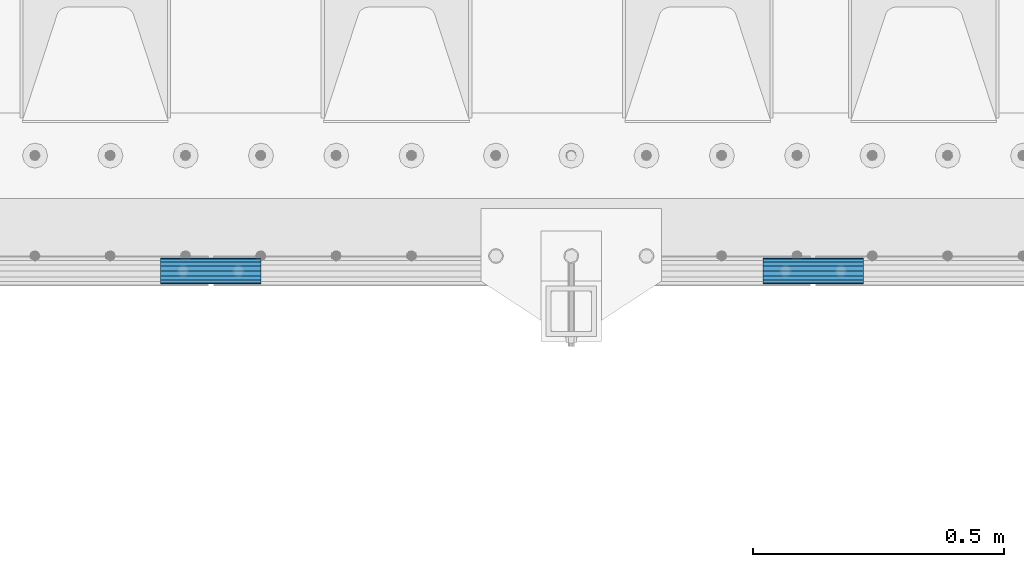
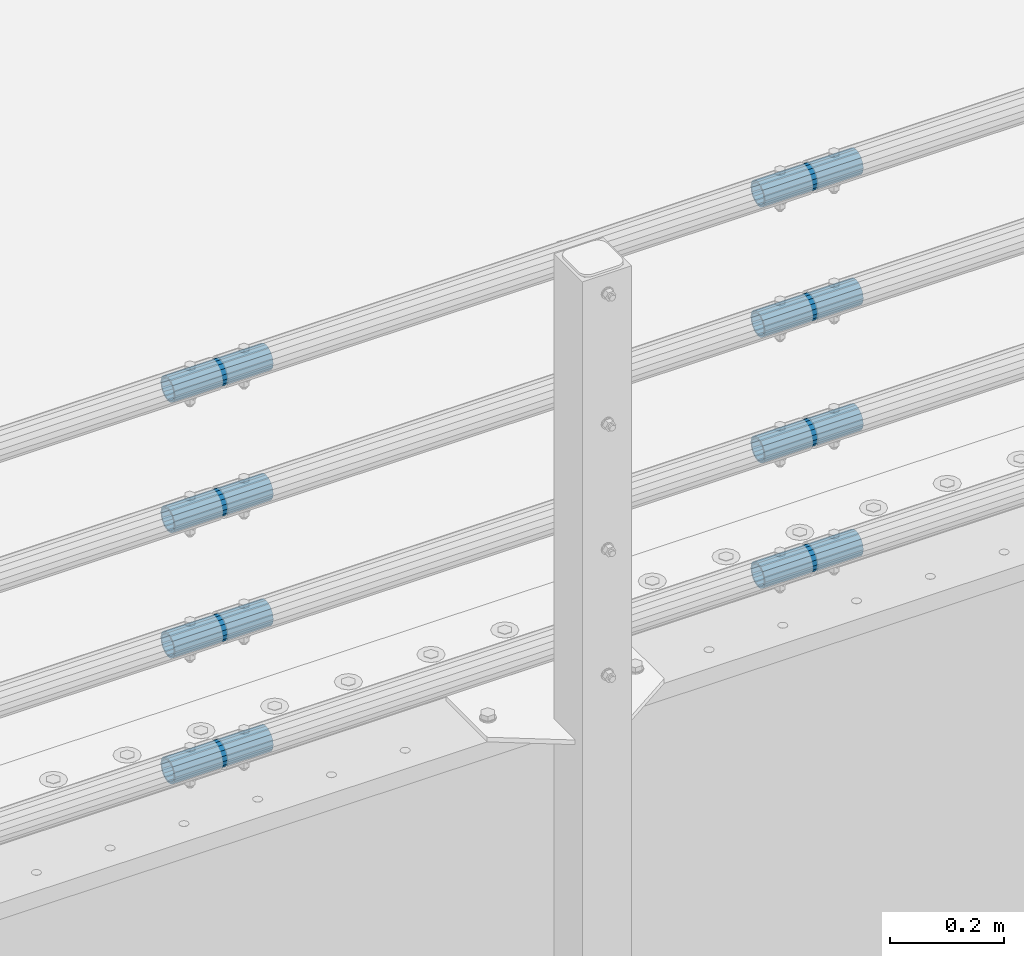
# One storey, part 156 of 242: 8 beams.
"""IFC2X3 building model written with IfcOpenShell, lengths in millimetres."""

import ifcopenshell
import ifcopenshell.guid

model = None  # the IFC model being written
_history = None  # IfcOwnerHistory: only IFC2X3 demands one
_inside = {}  # id of a spatial element -> (the spatial element, [elements in it])
_under = {}  # id of a project, library or spatial element -> (it, [spatial elements below it])
_declared = {}  # id of a project -> (the project, [libraries it declares])
_typed = {}  # id of a type object -> (the type object, [elements of that type])
_made_of = {}  # id of a material, layer set ... -> (it, [elements and type objects made of it])


def new_model(schema):
    """Start an empty IFC model of exactly this schema.

    Asked for "IFC4X3", IfcOpenShell would pick the latest addendum, in which some entities
    have other attributes; the version numbers below select the first issue.
    IFC2X3 requires an IfcOwnerHistory on every rooted entity: one is made here for all.
    """
    global model, _history
    if schema == "IFC4X3":
        model = ifcopenshell.file(schema_version=(4, 3, 0, 0))
    else:
        model = ifcopenshell.file(schema=schema)
    _inside.clear()
    _under.clear()
    _declared.clear()
    _typed.clear()
    _made_of.clear()
    _history = None
    if model.schema == "IFC2X3":
        org = make("IfcOrganization", Name="unknown")
        user = make(
            "IfcPersonAndOrganization",
            ThePerson=make("IfcPerson", FamilyName="unknown"),
            TheOrganization=org,
        )
        app = make(
            "IfcApplication",
            ApplicationDeveloper=org,
            Version="unknown",
            ApplicationFullName="unknown",
            ApplicationIdentifier="unknown",
        )
        _history = make(
            "IfcOwnerHistory",
            OwningUser=user,
            OwningApplication=app,
            ChangeAction="ADDED",
            CreationDate=0,
        )
    return model


def make(cls, **values):
    """One entity of the class cls with the attributes given. An attribute that is None is left unset."""
    return model.create_entity(
        cls, **{name: value for name, value in values.items() if value is not None}
    )


def rooted(cls, **values):
    """An entity with a GlobalId (a new one), such as an element, a storey or a relation."""
    return make(cls, GlobalId=ifcopenshell.guid.new(), OwnerHistory=_history, **values)


def si_unit(unit_type, name, prefix=None):
    """IfcSIUnit, for example si_unit("LENGTHUNIT", "METRE", prefix="MILLI")."""
    return make("IfcSIUnit", UnitType=unit_type, Prefix=prefix, Name=name)


def assignment(units):
    """IfcUnitAssignment: the units of a project."""
    return None if units is None else make("IfcUnitAssignment", Units=units)


def point(xyz):
    """IfcCartesianPoint."""
    return None if xyz is None else make("IfcCartesianPoint", Coordinates=xyz)


def direction(xyz):
    """IfcDirection."""
    return None if xyz is None else make("IfcDirection", DirectionRatios=xyz)


def frame(location, z_axis=None, x_axis=None):
    """IfcAxis2Placement3D, a coordinate frame: its origin and axes. An axis left out is left unset."""
    return make(
        "IfcAxis2Placement3D",
        Location=point(location),
        Axis=direction(z_axis),
        RefDirection=direction(x_axis),
    )


def origin_with_axes():
    """The frame at (0, 0, 0) with the z axis (0, 0, 1) and the x axis (1, 0, 0) written out."""
    return frame((0.0, 0.0, 0.0), z_axis=(0.0, 0.0, 1.0), x_axis=(1.0, 0.0, 0.0))


def place(relative_to, where):
    """IfcLocalPlacement: puts the frame where relative to a parent placement (None: the world)."""
    return make(
        "IfcLocalPlacement", PlacementRelTo=relative_to, RelativePlacement=where
    )


def context(
    kind, dimensions, precision=None, world=None, true_north=None, identifier=None
):
    """IfcGeometricRepresentationContext, for example the 3D "Model" context."""
    return make(
        "IfcGeometricRepresentationContext",
        ContextIdentifier=identifier,
        ContextType=kind,
        CoordinateSpaceDimension=dimensions,
        Precision=precision,
        WorldCoordinateSystem=world,
        TrueNorth=true_north,
    )


def subcontext(parent, identifier, kind, view, scale=None):
    """IfcGeometricRepresentationSubContext, for example "Body" below "Model"."""
    return make(
        "IfcGeometricRepresentationSubContext",
        ContextIdentifier=identifier,
        ContextType=kind,
        ParentContext=parent,
        TargetScale=scale,
        TargetView=view,
    )


def project(units=None, contexts=None):
    """IfcProject with its units and contexts."""
    return rooted(
        "IfcProject",
        Name="project",
        RepresentationContexts=contexts,
        UnitsInContext=assignment(units),
    )


def spatial(cls, under=None, at=None, **own):
    """A site, building, storey or space (cls), placed at a placement, below another one or the project."""
    s = rooted(cls, ObjectPlacement=at, **own)
    if under is not None:
        _under.setdefault(under.id(), (under, []))[1].append(s)
    return s


def faces_of(points, faces, orient=None, outer=None):
    """IfcFace entities. A face is a list of loops; a loop is a list of indices into points, from 0.

    orient and outer hold one flag for each loop. By default every Orientation is true, the
    first loop of a face is its IfcFaceOuterBound and the others are IfcFaceBound.
    """
    made = []
    for i, loops in enumerate(faces):
        bounds = []
        for j, loop in enumerate(loops):
            is_outer = j == 0 if outer is None else outer[i][j]
            bounds.append(
                make(
                    "IfcFaceOuterBound" if is_outer else "IfcFaceBound",
                    Bound=make("IfcPolyLoop", Polygon=[points[k] for k in loop]),
                    Orientation=True if orient is None else orient[i][j],
                )
            )
        made.append(make("IfcFace", Bounds=bounds))
    return made


def faceted_brep(points, faces, orient=None, outer=None, voids=None):
    """IfcFacetedBrep: a solid bounded by flat faces; with voids (closed shells), ...WithVoids."""
    shared = [point(p) for p in points]
    hull = make("IfcClosedShell", CfsFaces=faces_of(shared, faces, orient, outer))
    if voids is None:
        return make("IfcFacetedBrep", Outer=hull)
    return make(
        "IfcFacetedBrepWithVoids",
        Outer=hull,
        Voids=[
            make(cls, CfsFaces=faces_of(shared, fs, o, b)) for cls, fs, o, b in voids
        ],
    )


def shape(context_of_items, identifier, shape_type, items):
    """IfcShapeRepresentation: the items that make up one representation, for example the "Body"."""
    return make(
        "IfcShapeRepresentation",
        ContextOfItems=context_of_items,
        RepresentationIdentifier=identifier,
        RepresentationType=shape_type,
        Items=items,
    )


def material(Name=None, Category=None):
    """IfcMaterial."""
    return make("IfcMaterial", Name=Name, Category=Category)


def made_of(thing, what):
    """Note that an element or type object is made of a material, layer set ...; save() writes the relation."""
    if what is not None:
        _made_of.setdefault(what.id(), (what, []))[1].append(thing)
    return thing


def type_object(cls, material=None, **own):
    """A type object (cls), such as IfcWallType, which elements share."""
    return made_of(rooted(cls, **own), material)


def element(
    cls,
    number,
    at=None,
    inside=None,
    cuts=None,
    type_object=None,
    material=None,
    context=None,
    identifier="Body",
    shape_type=None,
    held_by="IfcProductDefinitionShape",
    body=None,
    shapes=None,
    **own,
):
    """One element of the class cls, such as IfcWall. Its Tag is "e" and its number.

    at: its placement. inside: the storey or other place that contains it. cuts: it is an
    opening in that element (IfcRelVoidsElement). A single representation is given by context,
    identifier, shape_type and body (its items); several are given by shapes. held_by: the class
    of the entity that holds the representations. save() writes the other relations.
    """
    e = rooted(cls, Tag="e%d" % number, ObjectPlacement=at, **own)
    if body is not None:
        shapes = [shape(context, identifier, shape_type, body)]
    if shapes is not None:
        e.Representation = make(held_by, Representations=shapes)
    if inside is not None:
        _inside.setdefault(inside.id(), (inside, []))[1].append(e)
    if cuts is not None:
        rooted(
            "IfcRelVoidsElement", RelatingBuildingElement=cuts, RelatedOpeningElement=e
        )
    if type_object is not None:
        _typed.setdefault(type_object.id(), (type_object, []))[1].append(e)
    return made_of(e, material)


def aggregate(whole, parts):
    """IfcRelAggregates: a whole, such as a stair, and the parts it consists of."""
    return rooted("IfcRelAggregates", RelatingObject=whole, RelatedObjects=parts)


def save(model, path):
    """Write the relations noted so far, then the file.

    IfcRelAggregates (storeys below a building ...), IfcRelContainedInSpatialStructure (elements
    in a storey), IfcRelDefinesByType, IfcRelAssociatesMaterial and IfcRelDeclares: one each for
    every whole, place, type object, material and project.
    """
    for whole, parts in _under.values():
        aggregate(whole, parts)
    for where, things in _inside.values():
        rooted(
            "IfcRelContainedInSpatialStructure",
            RelatedElements=things,
            RelatingStructure=where,
        )
    for kind, things in _typed.values():
        rooted("IfcRelDefinesByType", RelatedObjects=things, RelatingType=kind)
    for what, things in _made_of.values():
        rooted("IfcRelAssociatesMaterial", RelatedObjects=things, RelatingMaterial=what)
    for by, libraries in _declared.values():
        rooted("IfcRelDeclares", RelatingContext=by, RelatedDefinitions=libraries)
    model.write(path)


model = new_model("IFC2X3")

# Units and contexts
model_context = context("Model", 3, precision=1e-05, world=origin_with_axes())
body_context = subcontext(model_context, "Body", "Model", "MODEL_VIEW")
ifc_project = project(units=[si_unit("LENGTHUNIT", "METRE", prefix="MILLI"), si_unit("AREAUNIT", "SQUARE_METRE"), si_unit("VOLUMEUNIT", "CUBIC_METRE"), si_unit("MASSUNIT", "GRAM", prefix="KILO"), si_unit("TIMEUNIT", "SECOND"), si_unit("PLANEANGLEUNIT", "RADIAN"), si_unit("SOLIDANGLEUNIT", "STERADIAN"), si_unit("THERMODYNAMICTEMPERATUREUNIT", "DEGREE_CELSIUS"), si_unit("LUMINOUSINTENSITYUNIT", "LUMEN")], contexts=[model_context])

# Site, building, storey
site_placement = place(None, origin_with_axes())
site = spatial("IfcSite", under=ifc_project, at=site_placement, CompositionType="ELEMENT")
building_placement = place(site_placement, origin_with_axes())
building = spatial("IfcBuilding", under=site, at=building_placement, Name="Standard", CompositionType="ELEMENT")
storey_placement = place(building_placement, origin_with_axes())
storey = spatial("IfcBuildingStorey", under=building, at=storey_placement, Name="Undefined", CompositionType="ELEMENT", Elevation=0.0)

# Beams
ifc_material = material()
beam_type = type_object("IfcBeamType", PredefinedType="NOTDEFINED")
beam_1_placement = place(storey_placement, frame((-24850.0024970001, -24129.8499999996, 149.849999999726), z_axis=(0.0, 0.0, 1.0), x_axis=(1.0, 0.0, 0.0)))
element("IfcBeam", 1, at=beam_1_placement, inside=storey, type_object=beam_type, material=ifc_material, context=body_context, shape_type="Brep", body=[
    faceted_brep([(0.0, -21.9000000000015, 0.0), (0.0, -20.232961761998, 8.38076716879547), (200.0, -20.232961761998, 8.38076716879547), (200.0, -21.9000000000015, 0.0), (0.0, -15.4856385079838, 15.4856385079854), (200.0, -15.4856385079838, 15.4856385079854), (0.0, -8.38076716879368, 20.2329617619972), (200.0, -8.38076716879368, 20.2329617619972), (0.0, 0.0, 21.9), (200.0, 0.0, 21.9), (0.0, 8.38076716879368, 20.2329617619972), (200.0, 8.38076716879368, 20.2329617619972), (0.0, 15.4856385079838, 15.4856385079854), (200.0, 15.4856385079838, 15.4856385079854), (0.0, 20.232961761998, 8.38076716879547), (200.0, 20.232961761998, 8.38076716879547), (0.0, 21.9000000000015, 0.0), (200.0, 21.9000000000015, 0.0), (0.0, 20.232961761998, -8.38076716879547), (200.0, 20.232961761998, -8.38076716879547), (0.0, 15.4856385079838, -15.4856385079854), (200.0, 15.4856385079838, -15.4856385079854), (0.0, 8.38076716879368, -20.2329617619972), (200.0, 8.38076716879368, -20.2329617619972), (0.0, 0.0, -21.9), (200.0, 0.0, -21.9), (0.0, -8.38076716879368, -20.2329617619972), (200.0, -8.38076716879368, -20.2329617619972), (0.0, -15.4856385079838, -15.4856385079854), (200.0, -15.4856385079838, -15.4856385079854), (0.0, -20.232961761998, -8.38076716879547), (200.0, -20.232961761998, -8.38076716879547), (0.0, -25.5, 0.0), (0.0, -23.5589280790373, -9.7584275253098), (200.0, -23.5589280790373, -9.7584275253098), (200.0, -25.5, 0.0), (0.0, -18.0312229202573, -18.031222920257), (200.0, -18.0312229202573, -18.031222920257), (0.0, -9.75842752531025, -23.5589280790378), (200.0, -9.75842752531025, -23.5589280790378), (0.0, 0.0, -25.5), (200.0, 0.0, -25.5), (0.0, 9.75842752531025, -23.5589280790378), (200.0, 9.75842752531025, -23.5589280790378), (0.0, 18.0312229202573, -18.031222920257), (200.0, 18.0312229202573, -18.031222920257), (0.0, 23.5589280790373, -9.7584275253098), (200.0, 23.5589280790373, -9.7584275253098), (0.0, 25.5, 0.0), (200.0, 25.5, 0.0), (0.0, 23.5589280790373, 9.7584275253098), (200.0, 23.5589280790373, 9.7584275253098), (0.0, 18.0312229202573, 18.031222920257), (200.0, 18.0312229202573, 18.031222920257), (0.0, 9.75842752531025, 23.5589280790378), (200.0, 9.75842752531025, 23.5589280790378), (0.0, 0.0, 25.5), (200.0, 0.0, 25.5), (0.0, -9.75842752531025, 23.5589280790378), (200.0, -9.75842752531025, 23.5589280790378), (0.0, -18.0312229202573, 18.031222920257), (200.0, -18.0312229202573, 18.031222920257), (0.0, -23.5589280790373, 9.7584275253098), (200.0, -23.5589280790373, 9.7584275253098)], [[[0, 1, 2, 3]], [[1, 4, 5, 2]], [[4, 6, 7, 5]], [[6, 8, 9, 7]], [[8, 10, 11, 9]], [[10, 12, 13, 11]], [[12, 14, 15, 13]], [[14, 16, 17, 15]], [[16, 18, 19, 17]], [[18, 20, 21, 19]], [[20, 22, 23, 21]], [[22, 24, 25, 23]], [[24, 26, 27, 25]], [[26, 28, 29, 27]], [[28, 30, 31, 29]], [[30, 0, 3, 31]], [[32, 33, 34, 35]], [[33, 36, 37, 34]], [[36, 38, 39, 37]], [[38, 40, 41, 39]], [[40, 42, 43, 41]], [[42, 44, 45, 43]], [[44, 46, 47, 45]], [[46, 48, 49, 47]], [[48, 50, 51, 49]], [[50, 52, 53, 51]], [[52, 54, 55, 53]], [[54, 56, 57, 55]], [[56, 58, 59, 57]], [[58, 60, 61, 59]], [[60, 62, 63, 61]], [[62, 32, 35, 63]], [[37, 39, 41, 43, 45, 47, 49, 51, 53, 55, 57, 59, 61, 63, 35, 34], [5, 7, 9, 11, 13, 15, 17, 19, 21, 23, 25, 27, 29, 31, 3, 2]], [[62, 60, 58, 56, 54, 52, 50, 48, 46, 44, 42, 40, 38, 36, 33, 32], [30, 28, 26, 24, 22, 20, 18, 16, 14, 12, 10, 8, 6, 4, 1, 0]]]),
])
beam_2_placement = place(storey_placement, frame((-24850.0024970001, -24129.8499999996, 420.149999999725), z_axis=(0.0, 0.0, 1.0), x_axis=(1.0, 0.0, 0.0)))
element("IfcBeam", 2, at=beam_2_placement, inside=storey, type_object=beam_type, material=ifc_material, context=body_context, shape_type="Brep", body=[
    faceted_brep([(0.0, -21.9000000000015, 0.0), (0.0, -20.232961761998, 8.38076716879547), (200.0, -20.232961761998, 8.38076716879547), (200.0, -21.9000000000015, 0.0), (0.0, -15.4856385079838, 15.4856385079854), (200.0, -15.4856385079838, 15.4856385079854), (0.0, -8.38076716879368, 20.2329617619972), (200.0, -8.38076716879368, 20.2329617619972), (0.0, 0.0, 21.9), (200.0, 0.0, 21.9), (0.0, 8.38076716879368, 20.2329617619972), (200.0, 8.38076716879368, 20.2329617619972), (0.0, 15.4856385079838, 15.4856385079854), (200.0, 15.4856385079838, 15.4856385079854), (0.0, 20.232961761998, 8.38076716879547), (200.0, 20.232961761998, 8.38076716879547), (0.0, 21.9000000000015, 0.0), (200.0, 21.9000000000015, 0.0), (0.0, 20.232961761998, -8.38076716879547), (200.0, 20.232961761998, -8.38076716879547), (0.0, 15.4856385079838, -15.4856385079854), (200.0, 15.4856385079838, -15.4856385079854), (0.0, 8.38076716879368, -20.2329617619972), (200.0, 8.38076716879368, -20.2329617619972), (0.0, 0.0, -21.9), (200.0, 0.0, -21.9), (0.0, -8.38076716879368, -20.2329617619972), (200.0, -8.38076716879368, -20.2329617619972), (0.0, -15.4856385079838, -15.4856385079854), (200.0, -15.4856385079838, -15.4856385079854), (0.0, -20.232961761998, -8.38076716879547), (200.0, -20.232961761998, -8.38076716879547), (0.0, -25.5, 0.0), (0.0, -23.5589280790373, -9.7584275253098), (200.0, -23.5589280790373, -9.7584275253098), (200.0, -25.5, 0.0), (0.0, -18.0312229202573, -18.031222920257), (200.0, -18.0312229202573, -18.031222920257), (0.0, -9.75842752531025, -23.5589280790378), (200.0, -9.75842752531025, -23.5589280790378), (0.0, 0.0, -25.5), (200.0, 0.0, -25.5), (0.0, 9.75842752531025, -23.5589280790378), (200.0, 9.75842752531025, -23.5589280790378), (0.0, 18.0312229202573, -18.031222920257), (200.0, 18.0312229202573, -18.031222920257), (0.0, 23.5589280790373, -9.7584275253098), (200.0, 23.5589280790373, -9.7584275253098), (0.0, 25.5, 0.0), (200.0, 25.5, 0.0), (0.0, 23.5589280790373, 9.7584275253098), (200.0, 23.5589280790373, 9.7584275253098), (0.0, 18.0312229202573, 18.031222920257), (200.0, 18.0312229202573, 18.031222920257), (0.0, 9.75842752531025, 23.5589280790378), (200.0, 9.75842752531025, 23.5589280790378), (0.0, 0.0, 25.5), (200.0, 0.0, 25.5), (0.0, -9.75842752531025, 23.5589280790378), (200.0, -9.75842752531025, 23.5589280790378), (0.0, -18.0312229202573, 18.031222920257), (200.0, -18.0312229202573, 18.031222920257), (0.0, -23.5589280790373, 9.7584275253098), (200.0, -23.5589280790373, 9.7584275253098)], [[[0, 1, 2, 3]], [[1, 4, 5, 2]], [[4, 6, 7, 5]], [[6, 8, 9, 7]], [[8, 10, 11, 9]], [[10, 12, 13, 11]], [[12, 14, 15, 13]], [[14, 16, 17, 15]], [[16, 18, 19, 17]], [[18, 20, 21, 19]], [[20, 22, 23, 21]], [[22, 24, 25, 23]], [[24, 26, 27, 25]], [[26, 28, 29, 27]], [[28, 30, 31, 29]], [[30, 0, 3, 31]], [[32, 33, 34, 35]], [[33, 36, 37, 34]], [[36, 38, 39, 37]], [[38, 40, 41, 39]], [[40, 42, 43, 41]], [[42, 44, 45, 43]], [[44, 46, 47, 45]], [[46, 48, 49, 47]], [[48, 50, 51, 49]], [[50, 52, 53, 51]], [[52, 54, 55, 53]], [[54, 56, 57, 55]], [[56, 58, 59, 57]], [[58, 60, 61, 59]], [[60, 62, 63, 61]], [[62, 32, 35, 63]], [[37, 39, 41, 43, 45, 47, 49, 51, 53, 55, 57, 59, 61, 63, 35, 34], [5, 7, 9, 11, 13, 15, 17, 19, 21, 23, 25, 27, 29, 31, 3, 2]], [[62, 60, 58, 56, 54, 52, 50, 48, 46, 44, 42, 40, 38, 36, 33, 32], [30, 28, 26, 24, 22, 20, 18, 16, 14, 12, 10, 8, 6, 4, 1, 0]]]),
])
beam_3_placement = place(storey_placement, frame((-24850.0024970001, -24129.8499999996, 969.849999999726), z_axis=(0.0, 0.0, 1.0), x_axis=(1.0, 0.0, 0.0)))
element("IfcBeam", 3, at=beam_3_placement, inside=storey, type_object=beam_type, material=ifc_material, context=body_context, shape_type="Brep", body=[
    faceted_brep([(0.0, -21.9000000000015, 0.0), (0.0, -20.232961761998, 8.38076716879547), (200.0, -20.232961761998, 8.38076716879547), (200.0, -21.9000000000015, 0.0), (0.0, -15.4856385079838, 15.4856385079854), (200.0, -15.4856385079838, 15.4856385079854), (0.0, -8.38076716879368, 20.2329617619972), (200.0, -8.38076716879368, 20.2329617619972), (0.0, 0.0, 21.9), (200.0, 0.0, 21.9), (0.0, 8.38076716879368, 20.2329617619972), (200.0, 8.38076716879368, 20.2329617619972), (0.0, 15.4856385079838, 15.4856385079854), (200.0, 15.4856385079838, 15.4856385079854), (0.0, 20.232961761998, 8.38076716879547), (200.0, 20.232961761998, 8.38076716879547), (0.0, 21.9000000000015, 0.0), (200.0, 21.9000000000015, 0.0), (0.0, 20.232961761998, -8.38076716879547), (200.0, 20.232961761998, -8.38076716879547), (0.0, 15.4856385079838, -15.4856385079854), (200.0, 15.4856385079838, -15.4856385079854), (0.0, 8.38076716879368, -20.2329617619972), (200.0, 8.38076716879368, -20.2329617619972), (0.0, 0.0, -21.9), (200.0, 0.0, -21.9), (0.0, -8.38076716879368, -20.2329617619972), (200.0, -8.38076716879368, -20.2329617619972), (0.0, -15.4856385079838, -15.4856385079854), (200.0, -15.4856385079838, -15.4856385079854), (0.0, -20.232961761998, -8.38076716879547), (200.0, -20.232961761998, -8.38076716879547), (0.0, -25.5, 0.0), (0.0, -23.5589280790373, -9.7584275253098), (200.0, -23.5589280790373, -9.7584275253098), (200.0, -25.5, 0.0), (0.0, -18.0312229202573, -18.031222920257), (200.0, -18.0312229202573, -18.031222920257), (0.0, -9.75842752531025, -23.5589280790378), (200.0, -9.75842752531025, -23.5589280790378), (0.0, 0.0, -25.5), (200.0, 0.0, -25.5), (0.0, 9.75842752531025, -23.5589280790378), (200.0, 9.75842752531025, -23.5589280790378), (0.0, 18.0312229202573, -18.031222920257), (200.0, 18.0312229202573, -18.031222920257), (0.0, 23.5589280790373, -9.7584275253098), (200.0, 23.5589280790373, -9.7584275253098), (0.0, 25.5, 0.0), (200.0, 25.5, 0.0), (0.0, 23.5589280790373, 9.7584275253098), (200.0, 23.5589280790373, 9.7584275253098), (0.0, 18.0312229202573, 18.031222920257), (200.0, 18.0312229202573, 18.031222920257), (0.0, 9.75842752531025, 23.5589280790378), (200.0, 9.75842752531025, 23.5589280790378), (0.0, 0.0, 25.5), (200.0, 0.0, 25.5), (0.0, -9.75842752531025, 23.5589280790378), (200.0, -9.75842752531025, 23.5589280790378), (0.0, -18.0312229202573, 18.031222920257), (200.0, -18.0312229202573, 18.031222920257), (0.0, -23.5589280790373, 9.7584275253098), (200.0, -23.5589280790373, 9.7584275253098)], [[[0, 1, 2, 3]], [[1, 4, 5, 2]], [[4, 6, 7, 5]], [[6, 8, 9, 7]], [[8, 10, 11, 9]], [[10, 12, 13, 11]], [[12, 14, 15, 13]], [[14, 16, 17, 15]], [[16, 18, 19, 17]], [[18, 20, 21, 19]], [[20, 22, 23, 21]], [[22, 24, 25, 23]], [[24, 26, 27, 25]], [[26, 28, 29, 27]], [[28, 30, 31, 29]], [[30, 0, 3, 31]], [[32, 33, 34, 35]], [[33, 36, 37, 34]], [[36, 38, 39, 37]], [[38, 40, 41, 39]], [[40, 42, 43, 41]], [[42, 44, 45, 43]], [[44, 46, 47, 45]], [[46, 48, 49, 47]], [[48, 50, 51, 49]], [[50, 52, 53, 51]], [[52, 54, 55, 53]], [[54, 56, 57, 55]], [[56, 58, 59, 57]], [[58, 60, 61, 59]], [[60, 62, 63, 61]], [[62, 32, 35, 63]], [[37, 39, 41, 43, 45, 47, 49, 51, 53, 55, 57, 59, 61, 63, 35, 34], [5, 7, 9, 11, 13, 15, 17, 19, 21, 23, 25, 27, 29, 31, 3, 2]], [[62, 60, 58, 56, 54, 52, 50, 48, 46, 44, 42, 40, 38, 36, 33, 32], [30, 28, 26, 24, 22, 20, 18, 16, 14, 12, 10, 8, 6, 4, 1, 0]]]),
])
beam_4_placement = place(storey_placement, frame((-23650.0024970001, -24129.8499999996, 419.849999999726), z_axis=(0.0, 0.0, 1.0), x_axis=(1.0, 0.0, 0.0)))
element("IfcBeam", 4, at=beam_4_placement, inside=storey, type_object=beam_type, material=ifc_material, context=body_context, shape_type="Brep", body=[
    faceted_brep([(0.0, -21.9000000000015, 0.0), (0.0, -20.232961761998, 8.38076716879547), (200.0, -20.232961761998, 8.38076716879547), (200.0, -21.9000000000015, 0.0), (0.0, -15.4856385079838, 15.4856385079854), (200.0, -15.4856385079838, 15.4856385079854), (0.0, -8.38076716879368, 20.2329617619972), (200.0, -8.38076716879368, 20.2329617619972), (0.0, 0.0, 21.9), (200.0, 0.0, 21.9), (0.0, 8.38076716879368, 20.2329617619972), (200.0, 8.38076716879368, 20.2329617619972), (0.0, 15.4856385079838, 15.4856385079854), (200.0, 15.4856385079838, 15.4856385079854), (0.0, 20.232961761998, 8.38076716879547), (200.0, 20.232961761998, 8.38076716879547), (0.0, 21.9000000000015, 0.0), (200.0, 21.9000000000015, 0.0), (0.0, 20.232961761998, -8.38076716879547), (200.0, 20.232961761998, -8.38076716879547), (0.0, 15.4856385079838, -15.4856385079854), (200.0, 15.4856385079838, -15.4856385079854), (0.0, 8.38076716879368, -20.2329617619972), (200.0, 8.38076716879368, -20.2329617619972), (0.0, 0.0, -21.9), (200.0, 0.0, -21.9), (0.0, -8.38076716879368, -20.2329617619972), (200.0, -8.38076716879368, -20.2329617619972), (0.0, -15.4856385079838, -15.4856385079854), (200.0, -15.4856385079838, -15.4856385079854), (0.0, -20.232961761998, -8.38076716879547), (200.0, -20.232961761998, -8.38076716879547), (0.0, -25.5, 0.0), (0.0, -23.5589280790373, -9.7584275253098), (200.0, -23.5589280790373, -9.7584275253098), (200.0, -25.5, 0.0), (0.0, -18.0312229202573, -18.031222920257), (200.0, -18.0312229202573, -18.031222920257), (0.0, -9.75842752531025, -23.5589280790378), (200.0, -9.75842752531025, -23.5589280790378), (0.0, 0.0, -25.5), (200.0, 0.0, -25.5), (0.0, 9.75842752531025, -23.5589280790378), (200.0, 9.75842752531025, -23.5589280790378), (0.0, 18.0312229202573, -18.031222920257), (200.0, 18.0312229202573, -18.031222920257), (0.0, 23.5589280790373, -9.7584275253098), (200.0, 23.5589280790373, -9.7584275253098), (0.0, 25.5, 0.0), (200.0, 25.5, 0.0), (0.0, 23.5589280790373, 9.7584275253098), (200.0, 23.5589280790373, 9.7584275253098), (0.0, 18.0312229202573, 18.031222920257), (200.0, 18.0312229202573, 18.031222920257), (0.0, 9.75842752531025, 23.5589280790378), (200.0, 9.75842752531025, 23.5589280790378), (0.0, 0.0, 25.5), (200.0, 0.0, 25.5), (0.0, -9.75842752531025, 23.5589280790378), (200.0, -9.75842752531025, 23.5589280790378), (0.0, -18.0312229202573, 18.031222920257), (200.0, -18.0312229202573, 18.031222920257), (0.0, -23.5589280790373, 9.7584275253098), (200.0, -23.5589280790373, 9.7584275253098)], [[[0, 1, 2, 3]], [[1, 4, 5, 2]], [[4, 6, 7, 5]], [[6, 8, 9, 7]], [[8, 10, 11, 9]], [[10, 12, 13, 11]], [[12, 14, 15, 13]], [[14, 16, 17, 15]], [[16, 18, 19, 17]], [[18, 20, 21, 19]], [[20, 22, 23, 21]], [[22, 24, 25, 23]], [[24, 26, 27, 25]], [[26, 28, 29, 27]], [[28, 30, 31, 29]], [[30, 0, 3, 31]], [[32, 33, 34, 35]], [[33, 36, 37, 34]], [[36, 38, 39, 37]], [[38, 40, 41, 39]], [[40, 42, 43, 41]], [[42, 44, 45, 43]], [[44, 46, 47, 45]], [[46, 48, 49, 47]], [[48, 50, 51, 49]], [[50, 52, 53, 51]], [[52, 54, 55, 53]], [[54, 56, 57, 55]], [[56, 58, 59, 57]], [[58, 60, 61, 59]], [[60, 62, 63, 61]], [[62, 32, 35, 63]], [[37, 39, 41, 43, 45, 47, 49, 51, 53, 55, 57, 59, 61, 63, 35, 34], [5, 7, 9, 11, 13, 15, 17, 19, 21, 23, 25, 27, 29, 31, 3, 2]], [[62, 60, 58, 56, 54, 52, 50, 48, 46, 44, 42, 40, 38, 36, 33, 32], [30, 28, 26, 24, 22, 20, 18, 16, 14, 12, 10, 8, 6, 4, 1, 0]]]),
])
beam_5_placement = place(storey_placement, frame((-23650.0024970001, -24129.8499999996, 149.849999999726), z_axis=(0.0, 0.0, 1.0), x_axis=(1.0, 0.0, 0.0)))
element("IfcBeam", 5, at=beam_5_placement, inside=storey, type_object=beam_type, material=ifc_material, context=body_context, shape_type="Brep", body=[
    faceted_brep([(0.0, -21.9000000000015, 0.0), (0.0, -20.232961761998, 8.38076716879547), (200.0, -20.232961761998, 8.38076716879547), (200.0, -21.9000000000015, 0.0), (0.0, -15.4856385079838, 15.4856385079854), (200.0, -15.4856385079838, 15.4856385079854), (0.0, -8.38076716879368, 20.2329617619972), (200.0, -8.38076716879368, 20.2329617619972), (0.0, 0.0, 21.9), (200.0, 0.0, 21.9), (0.0, 8.38076716879368, 20.2329617619972), (200.0, 8.38076716879368, 20.2329617619972), (0.0, 15.4856385079838, 15.4856385079854), (200.0, 15.4856385079838, 15.4856385079854), (0.0, 20.232961761998, 8.38076716879547), (200.0, 20.232961761998, 8.38076716879547), (0.0, 21.9000000000015, 0.0), (200.0, 21.9000000000015, 0.0), (0.0, 20.232961761998, -8.38076716879547), (200.0, 20.232961761998, -8.38076716879547), (0.0, 15.4856385079838, -15.4856385079854), (200.0, 15.4856385079838, -15.4856385079854), (0.0, 8.38076716879368, -20.2329617619972), (200.0, 8.38076716879368, -20.2329617619972), (0.0, 0.0, -21.9), (200.0, 0.0, -21.9), (0.0, -8.38076716879368, -20.2329617619972), (200.0, -8.38076716879368, -20.2329617619972), (0.0, -15.4856385079838, -15.4856385079854), (200.0, -15.4856385079838, -15.4856385079854), (0.0, -20.232961761998, -8.38076716879547), (200.0, -20.232961761998, -8.38076716879547), (0.0, -25.5, 0.0), (0.0, -23.5589280790373, -9.7584275253098), (200.0, -23.5589280790373, -9.7584275253098), (200.0, -25.5, 0.0), (0.0, -18.0312229202573, -18.031222920257), (200.0, -18.0312229202573, -18.031222920257), (0.0, -9.75842752531025, -23.5589280790378), (200.0, -9.75842752531025, -23.5589280790378), (0.0, 0.0, -25.5), (200.0, 0.0, -25.5), (0.0, 9.75842752531025, -23.5589280790378), (200.0, 9.75842752531025, -23.5589280790378), (0.0, 18.0312229202573, -18.031222920257), (200.0, 18.0312229202573, -18.031222920257), (0.0, 23.5589280790373, -9.7584275253098), (200.0, 23.5589280790373, -9.7584275253098), (0.0, 25.5, 0.0), (200.0, 25.5, 0.0), (0.0, 23.5589280790373, 9.7584275253098), (200.0, 23.5589280790373, 9.7584275253098), (0.0, 18.0312229202573, 18.031222920257), (200.0, 18.0312229202573, 18.031222920257), (0.0, 9.75842752531025, 23.5589280790378), (200.0, 9.75842752531025, 23.5589280790378), (0.0, 0.0, 25.5), (200.0, 0.0, 25.5), (0.0, -9.75842752531025, 23.5589280790378), (200.0, -9.75842752531025, 23.5589280790378), (0.0, -18.0312229202573, 18.031222920257), (200.0, -18.0312229202573, 18.031222920257), (0.0, -23.5589280790373, 9.7584275253098), (200.0, -23.5589280790373, 9.7584275253098)], [[[0, 1, 2, 3]], [[1, 4, 5, 2]], [[4, 6, 7, 5]], [[6, 8, 9, 7]], [[8, 10, 11, 9]], [[10, 12, 13, 11]], [[12, 14, 15, 13]], [[14, 16, 17, 15]], [[16, 18, 19, 17]], [[18, 20, 21, 19]], [[20, 22, 23, 21]], [[22, 24, 25, 23]], [[24, 26, 27, 25]], [[26, 28, 29, 27]], [[28, 30, 31, 29]], [[30, 0, 3, 31]], [[32, 33, 34, 35]], [[33, 36, 37, 34]], [[36, 38, 39, 37]], [[38, 40, 41, 39]], [[40, 42, 43, 41]], [[42, 44, 45, 43]], [[44, 46, 47, 45]], [[46, 48, 49, 47]], [[48, 50, 51, 49]], [[50, 52, 53, 51]], [[52, 54, 55, 53]], [[54, 56, 57, 55]], [[56, 58, 59, 57]], [[58, 60, 61, 59]], [[60, 62, 63, 61]], [[62, 32, 35, 63]], [[37, 39, 41, 43, 45, 47, 49, 51, 53, 55, 57, 59, 61, 63, 35, 34], [5, 7, 9, 11, 13, 15, 17, 19, 21, 23, 25, 27, 29, 31, 3, 2]], [[62, 60, 58, 56, 54, 52, 50, 48, 46, 44, 42, 40, 38, 36, 33, 32], [30, 28, 26, 24, 22, 20, 18, 16, 14, 12, 10, 8, 6, 4, 1, 0]]]),
])
beam_6_placement = place(storey_placement, frame((-23650.0024970001, -24129.8499999996, 689.849999999726), z_axis=(0.0, 0.0, 1.0), x_axis=(1.0, 0.0, 0.0)))
element("IfcBeam", 6, at=beam_6_placement, inside=storey, type_object=beam_type, material=ifc_material, context=body_context, shape_type="Brep", body=[
    faceted_brep([(0.0, -21.9000000000015, 0.0), (0.0, -20.232961761998, 8.38076716879547), (200.0, -20.232961761998, 8.38076716879547), (200.0, -21.9000000000015, 0.0), (0.0, -15.4856385079838, 15.4856385079854), (200.0, -15.4856385079838, 15.4856385079854), (0.0, -8.38076716879368, 20.2329617619972), (200.0, -8.38076716879368, 20.2329617619972), (0.0, 0.0, 21.9), (200.0, 0.0, 21.9), (0.0, 8.38076716879368, 20.2329617619972), (200.0, 8.38076716879368, 20.2329617619972), (0.0, 15.4856385079838, 15.4856385079854), (200.0, 15.4856385079838, 15.4856385079854), (0.0, 20.232961761998, 8.38076716879547), (200.0, 20.232961761998, 8.38076716879547), (0.0, 21.9000000000015, 0.0), (200.0, 21.9000000000015, 0.0), (0.0, 20.232961761998, -8.38076716879547), (200.0, 20.232961761998, -8.38076716879547), (0.0, 15.4856385079838, -15.4856385079854), (200.0, 15.4856385079838, -15.4856385079854), (0.0, 8.38076716879368, -20.2329617619972), (200.0, 8.38076716879368, -20.2329617619972), (0.0, 0.0, -21.9), (200.0, 0.0, -21.9), (0.0, -8.38076716879368, -20.2329617619972), (200.0, -8.38076716879368, -20.2329617619972), (0.0, -15.4856385079838, -15.4856385079854), (200.0, -15.4856385079838, -15.4856385079854), (0.0, -20.232961761998, -8.38076716879547), (200.0, -20.232961761998, -8.38076716879547), (0.0, -25.5, 0.0), (0.0, -23.5589280790373, -9.7584275253098), (200.0, -23.5589280790373, -9.7584275253098), (200.0, -25.5, 0.0), (0.0, -18.0312229202573, -18.031222920257), (200.0, -18.0312229202573, -18.031222920257), (0.0, -9.75842752531025, -23.5589280790378), (200.0, -9.75842752531025, -23.5589280790378), (0.0, 0.0, -25.5), (200.0, 0.0, -25.5), (0.0, 9.75842752531025, -23.5589280790378), (200.0, 9.75842752531025, -23.5589280790378), (0.0, 18.0312229202573, -18.031222920257), (200.0, 18.0312229202573, -18.031222920257), (0.0, 23.5589280790373, -9.7584275253098), (200.0, 23.5589280790373, -9.7584275253098), (0.0, 25.5, 0.0), (200.0, 25.5, 0.0), (0.0, 23.5589280790373, 9.7584275253098), (200.0, 23.5589280790373, 9.7584275253098), (0.0, 18.0312229202573, 18.031222920257), (200.0, 18.0312229202573, 18.031222920257), (0.0, 9.75842752531025, 23.5589280790378), (200.0, 9.75842752531025, 23.5589280790378), (0.0, 0.0, 25.5), (200.0, 0.0, 25.5), (0.0, -9.75842752531025, 23.5589280790378), (200.0, -9.75842752531025, 23.5589280790378), (0.0, -18.0312229202573, 18.031222920257), (200.0, -18.0312229202573, 18.031222920257), (0.0, -23.5589280790373, 9.7584275253098), (200.0, -23.5589280790373, 9.7584275253098)], [[[0, 1, 2, 3]], [[1, 4, 5, 2]], [[4, 6, 7, 5]], [[6, 8, 9, 7]], [[8, 10, 11, 9]], [[10, 12, 13, 11]], [[12, 14, 15, 13]], [[14, 16, 17, 15]], [[16, 18, 19, 17]], [[18, 20, 21, 19]], [[20, 22, 23, 21]], [[22, 24, 25, 23]], [[24, 26, 27, 25]], [[26, 28, 29, 27]], [[28, 30, 31, 29]], [[30, 0, 3, 31]], [[32, 33, 34, 35]], [[33, 36, 37, 34]], [[36, 38, 39, 37]], [[38, 40, 41, 39]], [[40, 42, 43, 41]], [[42, 44, 45, 43]], [[44, 46, 47, 45]], [[46, 48, 49, 47]], [[48, 50, 51, 49]], [[50, 52, 53, 51]], [[52, 54, 55, 53]], [[54, 56, 57, 55]], [[56, 58, 59, 57]], [[58, 60, 61, 59]], [[60, 62, 63, 61]], [[62, 32, 35, 63]], [[37, 39, 41, 43, 45, 47, 49, 51, 53, 55, 57, 59, 61, 63, 35, 34], [5, 7, 9, 11, 13, 15, 17, 19, 21, 23, 25, 27, 29, 31, 3, 2]], [[62, 60, 58, 56, 54, 52, 50, 48, 46, 44, 42, 40, 38, 36, 33, 32], [30, 28, 26, 24, 22, 20, 18, 16, 14, 12, 10, 8, 6, 4, 1, 0]]]),
])
beam_7_placement = place(storey_placement, frame((-23650.0024970001, -24129.8499999995, 969.849999999726), z_axis=(0.0, 0.0, 1.0), x_axis=(1.0, 0.0, 0.0)))
element("IfcBeam", 7, at=beam_7_placement, inside=storey, type_object=beam_type, material=ifc_material, context=body_context, shape_type="Brep", body=[
    faceted_brep([(0.0, -21.9000000000015, 0.0), (0.0, -20.232961761998, 8.38076716879547), (200.0, -20.232961761998, 8.38076716879547), (200.0, -21.9000000000015, 0.0), (0.0, -15.4856385079838, 15.4856385079854), (200.0, -15.4856385079838, 15.4856385079854), (0.0, -8.38076716879368, 20.2329617619972), (200.0, -8.38076716879368, 20.2329617619972), (0.0, 0.0, 21.9), (200.0, 0.0, 21.9), (0.0, 8.38076716879368, 20.2329617619972), (200.0, 8.38076716879368, 20.2329617619972), (0.0, 15.4856385079838, 15.4856385079854), (200.0, 15.4856385079838, 15.4856385079854), (0.0, 20.232961761998, 8.38076716879547), (200.0, 20.232961761998, 8.38076716879547), (0.0, 21.9000000000015, 0.0), (200.0, 21.9000000000015, 0.0), (0.0, 20.232961761998, -8.38076716879547), (200.0, 20.232961761998, -8.38076716879547), (0.0, 15.4856385079838, -15.4856385079854), (200.0, 15.4856385079838, -15.4856385079854), (0.0, 8.38076716879368, -20.2329617619972), (200.0, 8.38076716879368, -20.2329617619972), (0.0, 0.0, -21.9), (200.0, 0.0, -21.9), (0.0, -8.38076716879368, -20.2329617619972), (200.0, -8.38076716879368, -20.2329617619972), (0.0, -15.4856385079838, -15.4856385079854), (200.0, -15.4856385079838, -15.4856385079854), (0.0, -20.232961761998, -8.38076716879547), (200.0, -20.232961761998, -8.38076716879547), (0.0, -25.5, 0.0), (0.0, -23.5589280790373, -9.7584275253098), (200.0, -23.5589280790373, -9.7584275253098), (200.0, -25.5, 0.0), (0.0, -18.0312229202573, -18.031222920257), (200.0, -18.0312229202573, -18.031222920257), (0.0, -9.75842752531025, -23.5589280790378), (200.0, -9.75842752531025, -23.5589280790378), (0.0, 0.0, -25.5), (200.0, 0.0, -25.5), (0.0, 9.75842752531025, -23.5589280790378), (200.0, 9.75842752531025, -23.5589280790378), (0.0, 18.0312229202573, -18.031222920257), (200.0, 18.0312229202573, -18.031222920257), (0.0, 23.5589280790373, -9.7584275253098), (200.0, 23.5589280790373, -9.7584275253098), (0.0, 25.5, 0.0), (200.0, 25.5, 0.0), (0.0, 23.5589280790373, 9.7584275253098), (200.0, 23.5589280790373, 9.7584275253098), (0.0, 18.0312229202573, 18.031222920257), (200.0, 18.0312229202573, 18.031222920257), (0.0, 9.75842752531025, 23.5589280790378), (200.0, 9.75842752531025, 23.5589280790378), (0.0, 0.0, 25.5), (200.0, 0.0, 25.5), (0.0, -9.75842752531025, 23.5589280790378), (200.0, -9.75842752531025, 23.5589280790378), (0.0, -18.0312229202573, 18.031222920257), (200.0, -18.0312229202573, 18.031222920257), (0.0, -23.5589280790373, 9.7584275253098), (200.0, -23.5589280790373, 9.7584275253098)], [[[0, 1, 2, 3]], [[1, 4, 5, 2]], [[4, 6, 7, 5]], [[6, 8, 9, 7]], [[8, 10, 11, 9]], [[10, 12, 13, 11]], [[12, 14, 15, 13]], [[14, 16, 17, 15]], [[16, 18, 19, 17]], [[18, 20, 21, 19]], [[20, 22, 23, 21]], [[22, 24, 25, 23]], [[24, 26, 27, 25]], [[26, 28, 29, 27]], [[28, 30, 31, 29]], [[30, 0, 3, 31]], [[32, 33, 34, 35]], [[33, 36, 37, 34]], [[36, 38, 39, 37]], [[38, 40, 41, 39]], [[40, 42, 43, 41]], [[42, 44, 45, 43]], [[44, 46, 47, 45]], [[46, 48, 49, 47]], [[48, 50, 51, 49]], [[50, 52, 53, 51]], [[52, 54, 55, 53]], [[54, 56, 57, 55]], [[56, 58, 59, 57]], [[58, 60, 61, 59]], [[60, 62, 63, 61]], [[62, 32, 35, 63]], [[37, 39, 41, 43, 45, 47, 49, 51, 53, 55, 57, 59, 61, 63, 35, 34], [5, 7, 9, 11, 13, 15, 17, 19, 21, 23, 25, 27, 29, 31, 3, 2]], [[62, 60, 58, 56, 54, 52, 50, 48, 46, 44, 42, 40, 38, 36, 33, 32], [30, 28, 26, 24, 22, 20, 18, 16, 14, 12, 10, 8, 6, 4, 1, 0]]]),
])
beam_8_placement = place(storey_placement, frame((-24850.0024970001, -24129.8499999996, 689.849999999726), z_axis=(0.0, 0.0, 1.0), x_axis=(1.0, 0.0, 0.0)))
element("IfcBeam", 8, at=beam_8_placement, inside=storey, type_object=beam_type, material=ifc_material, context=body_context, shape_type="Brep", body=[
    faceted_brep([(0.0, -21.9000000000015, 0.0), (0.0, -20.232961761998, 8.38076716879547), (200.0, -20.232961761998, 8.38076716879547), (200.0, -21.9000000000015, 0.0), (0.0, -15.4856385079838, 15.4856385079854), (200.0, -15.4856385079838, 15.4856385079854), (0.0, -8.38076716879368, 20.2329617619972), (200.0, -8.38076716879368, 20.2329617619972), (0.0, 0.0, 21.9), (200.0, 0.0, 21.9), (0.0, 8.38076716879368, 20.2329617619972), (200.0, 8.38076716879368, 20.2329617619972), (0.0, 15.4856385079838, 15.4856385079854), (200.0, 15.4856385079838, 15.4856385079854), (0.0, 20.232961761998, 8.38076716879547), (200.0, 20.232961761998, 8.38076716879547), (0.0, 21.9000000000015, 0.0), (200.0, 21.9000000000015, 0.0), (0.0, 20.232961761998, -8.38076716879547), (200.0, 20.232961761998, -8.38076716879547), (0.0, 15.4856385079838, -15.4856385079854), (200.0, 15.4856385079838, -15.4856385079854), (0.0, 8.38076716879368, -20.2329617619972), (200.0, 8.38076716879368, -20.2329617619972), (0.0, 0.0, -21.9), (200.0, 0.0, -21.9), (0.0, -8.38076716879368, -20.2329617619972), (200.0, -8.38076716879368, -20.2329617619972), (0.0, -15.4856385079838, -15.4856385079854), (200.0, -15.4856385079838, -15.4856385079854), (0.0, -20.232961761998, -8.38076716879547), (200.0, -20.232961761998, -8.38076716879547), (0.0, -25.5, 0.0), (0.0, -23.5589280790373, -9.7584275253098), (200.0, -23.5589280790373, -9.7584275253098), (200.0, -25.5, 0.0), (0.0, -18.0312229202573, -18.031222920257), (200.0, -18.0312229202573, -18.031222920257), (0.0, -9.75842752531025, -23.5589280790378), (200.0, -9.75842752531025, -23.5589280790378), (0.0, 0.0, -25.5), (200.0, 0.0, -25.5), (0.0, 9.75842752531025, -23.5589280790378), (200.0, 9.75842752531025, -23.5589280790378), (0.0, 18.0312229202573, -18.031222920257), (200.0, 18.0312229202573, -18.031222920257), (0.0, 23.5589280790373, -9.7584275253098), (200.0, 23.5589280790373, -9.7584275253098), (0.0, 25.5, 0.0), (200.0, 25.5, 0.0), (0.0, 23.5589280790373, 9.7584275253098), (200.0, 23.5589280790373, 9.7584275253098), (0.0, 18.0312229202573, 18.031222920257), (200.0, 18.0312229202573, 18.031222920257), (0.0, 9.75842752531025, 23.5589280790378), (200.0, 9.75842752531025, 23.5589280790378), (0.0, 0.0, 25.5), (200.0, 0.0, 25.5), (0.0, -9.75842752531025, 23.5589280790378), (200.0, -9.75842752531025, 23.5589280790378), (0.0, -18.0312229202573, 18.031222920257), (200.0, -18.0312229202573, 18.031222920257), (0.0, -23.5589280790373, 9.7584275253098), (200.0, -23.5589280790373, 9.7584275253098)], [[[0, 1, 2, 3]], [[1, 4, 5, 2]], [[4, 6, 7, 5]], [[6, 8, 9, 7]], [[8, 10, 11, 9]], [[10, 12, 13, 11]], [[12, 14, 15, 13]], [[14, 16, 17, 15]], [[16, 18, 19, 17]], [[18, 20, 21, 19]], [[20, 22, 23, 21]], [[22, 24, 25, 23]], [[24, 26, 27, 25]], [[26, 28, 29, 27]], [[28, 30, 31, 29]], [[30, 0, 3, 31]], [[32, 33, 34, 35]], [[33, 36, 37, 34]], [[36, 38, 39, 37]], [[38, 40, 41, 39]], [[40, 42, 43, 41]], [[42, 44, 45, 43]], [[44, 46, 47, 45]], [[46, 48, 49, 47]], [[48, 50, 51, 49]], [[50, 52, 53, 51]], [[52, 54, 55, 53]], [[54, 56, 57, 55]], [[56, 58, 59, 57]], [[58, 60, 61, 59]], [[60, 62, 63, 61]], [[62, 32, 35, 63]], [[37, 39, 41, 43, 45, 47, 49, 51, 53, 55, 57, 59, 61, 63, 35, 34], [5, 7, 9, 11, 13, 15, 17, 19, 21, 23, 25, 27, 29, 31, 3, 2]], [[62, 60, 58, 56, 54, 52, 50, 48, 46, 44, 42, 40, 38, 36, 33, 32], [30, 28, 26, 24, 22, 20, 18, 16, 14, 12, 10, 8, 6, 4, 1, 0]]]),
])

save(model, "model.ifc")
